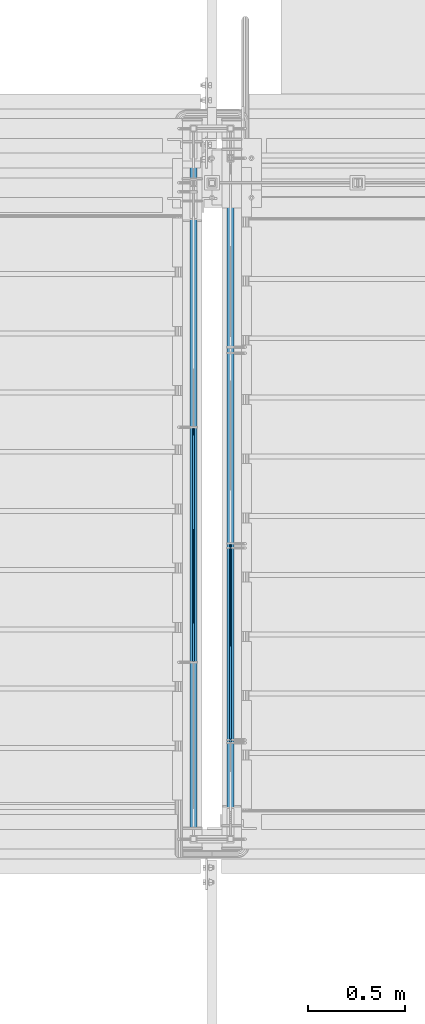
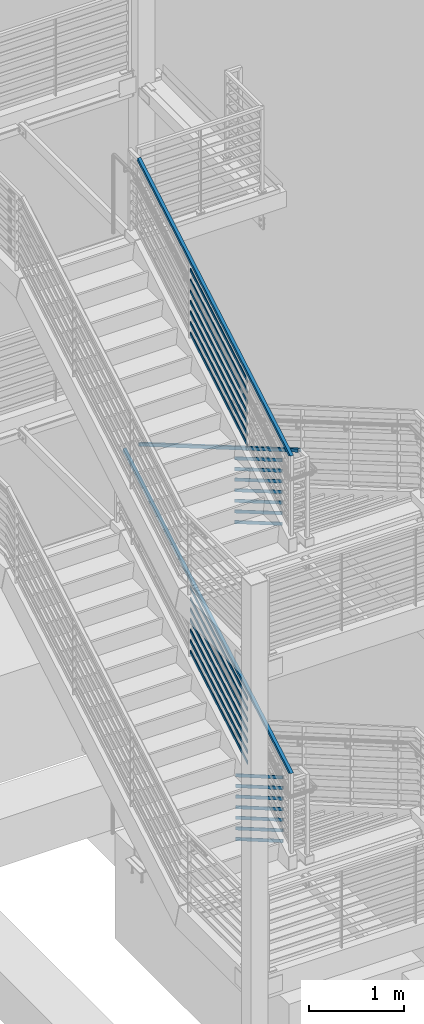
# One storey, part 755 of 1179: 31 members, 4 elements without a shape of their own.
"""IFC2X3 building model written with IfcOpenShell, lengths in millimetres."""

from ifc_helpers import new_model, si_unit, frame, origin_with_axes, place, context, subcontext, project, spatial, faceted_brep, material, type_object, element, aggregate, save


model = new_model("IFC2X3")

# Units and contexts
model_context = context("Model", 3, precision=1e-05, world=origin_with_axes())
body_context = subcontext(model_context, "Body", "Model", "MODEL_VIEW")
ifc_project = project(units=[si_unit("LENGTHUNIT", "METRE", prefix="MILLI"), si_unit("AREAUNIT", "SQUARE_METRE"), si_unit("VOLUMEUNIT", "CUBIC_METRE"), si_unit("MASSUNIT", "GRAM", prefix="KILO"), si_unit("TIMEUNIT", "SECOND"), si_unit("PLANEANGLEUNIT", "RADIAN"), si_unit("SOLIDANGLEUNIT", "STERADIAN"), si_unit("THERMODYNAMICTEMPERATUREUNIT", "DEGREE_CELSIUS"), si_unit("LUMINOUSINTENSITYUNIT", "LUMEN")], contexts=[model_context])

# Site, building, storey
site_placement = place(None, origin_with_axes())
site = spatial("IfcSite", under=ifc_project, at=site_placement, CompositionType="ELEMENT")
building_placement = place(site_placement, origin_with_axes())
building = spatial("IfcBuilding", under=site, at=building_placement, Name="Undefined", CompositionType="ELEMENT")
storey_placement = place(building_placement, origin_with_axes())
storey = spatial("IfcBuildingStorey", under=building, at=storey_placement, Name="Undefined", CompositionType="ELEMENT", Elevation=0.0)

# Assembly, members
assembly_1_placement = place(storey_placement, origin_with_axes())
assembly_1 = element("IfcElementAssembly", 1, at=assembly_1_placement, inside=storey, Name="GUARDRAIL", AssemblyPlace="NOTDEFINED", PredefinedType="RIGID_FRAME")
ifc_material_1 = material(Name="STEEL/A36")
member_type_1 = type_object("IfcMemberType", PredefinedType="NOTDEFINED")
member_1_placement = place(assembly_1_placement, frame((-1847.85000153055, 33867.7987430395, 7638.46554249568), z_axis=(0.0, -0.503871025834967, 0.863778900717086), x_axis=(0.0, -0.863778900717086, -0.503871025834967)))
member_1 = element("IfcMember", 2, at=member_1_placement, type_object=member_type_1, material=ifc_material_1, Name="PLATE", context=body_context, shape_type="Brep", body=[
    faceted_brep([(27.7385637234547, 4.76250000000005, -19.0500000000011), (5.51356370517169, 4.76250000000005, 19.0500000000338), (1396.15685487731, 4.76250000000005, 19.0500000012689), (1418.38185489559, 4.76250000000005, -19.049999998766), (5.51356370517169, -4.76250000000005, 19.0500000000338), (1396.15685487731, -4.76250000000005, 19.0500000012689), (27.7385637234547, -4.76250000000005, -19.0500000000011), (1418.38185489559, -4.76250000000005, -19.049999998766)], [[[0, 1, 2, 3]], [[1, 4, 5, 2]], [[4, 6, 7, 5]], [[6, 0, 3, 7]], [[5, 7, 3, 2]], [[6, 4, 1, 0]]]),
])
member_2_placement = place(assembly_1_placement, frame((-1847.85000153055, 33867.7987430395, 7774.64905217142), z_axis=(0.0, -0.503871025834967, 0.863778900717086), x_axis=(0.0, -0.863778900717086, -0.503871025834967)))
member_2 = element("IfcMember", 3, at=member_2_placement, type_object=member_type_1, material=ifc_material_1, Name="PLATE", context=body_context, shape_type="Brep", body=[
    faceted_brep([(27.7385637234547, 4.76250000000005, -19.0500000000011), (5.51356370517169, 4.76250000000005, 19.0500000000338), (1396.15685487731, 4.76250000000005, 19.0500000012689), (1418.38185489559, 4.76250000000005, -19.049999998766), (5.51356370517169, -4.76250000000005, 19.0500000000338), (1396.15685487731, -4.76250000000005, 19.0500000012689), (27.7385637234547, -4.76250000000005, -19.0500000000011), (1418.38185489559, -4.76250000000005, -19.049999998766)], [[[0, 1, 2, 3]], [[1, 4, 5, 2]], [[4, 6, 7, 5]], [[6, 0, 3, 7]], [[5, 7, 3, 2]], [[6, 4, 1, 0]]]),
])
member_3_placement = place(assembly_1_placement, frame((-1847.85000153055, 33867.7987430394, 7910.83256184716), z_axis=(0.0, -0.503871025834967, 0.863778900717086), x_axis=(0.0, -0.863778900717086, -0.503871025834967)))
member_3 = element("IfcMember", 4, at=member_3_placement, type_object=member_type_1, material=ifc_material_1, Name="PLATE", context=body_context, shape_type="Brep", body=[
    faceted_brep([(27.7385637234547, 4.76250000000005, -19.0500000000011), (5.51356370517169, 4.76250000000005, 19.0500000000338), (1396.15685487731, 4.76250000000005, 19.0500000012689), (1418.38185489559, 4.76250000000005, -19.049999998766), (5.51356370517169, -4.76250000000005, 19.0500000000338), (1396.15685487731, -4.76250000000005, 19.0500000012689), (27.7385637234547, -4.76250000000005, -19.0500000000011), (1418.38185489559, -4.76250000000005, -19.049999998766)], [[[0, 1, 2, 3]], [[1, 4, 5, 2]], [[4, 6, 7, 5]], [[6, 0, 3, 7]], [[5, 7, 3, 2]], [[6, 4, 1, 0]]]),
])
member_4_placement = place(assembly_1_placement, frame((-1847.85000153055, 33867.7987430394, 8047.01607152291), z_axis=(0.0, -0.503871025834967, 0.863778900717086), x_axis=(0.0, -0.863778900717086, -0.503871025834967)))
member_4 = element("IfcMember", 5, at=member_4_placement, type_object=member_type_1, material=ifc_material_1, Name="PLATE", context=body_context, shape_type="Brep", body=[
    faceted_brep([(27.7385637234547, 4.76250000000005, -19.0500000000011), (5.51356370517169, 4.76250000000005, 19.0500000000338), (1396.15685487731, 4.76250000000005, 19.0500000012689), (1418.38185489559, 4.76250000000005, -19.049999998766), (5.51356370517169, -4.76250000000005, 19.0500000000338), (1396.15685487731, -4.76250000000005, 19.0500000012689), (27.7385637234547, -4.76250000000005, -19.0500000000011), (1418.38185489559, -4.76250000000005, -19.049999998766)], [[[0, 1, 2, 3]], [[1, 4, 5, 2]], [[4, 6, 7, 5]], [[6, 0, 3, 7]], [[5, 7, 3, 2]], [[6, 4, 1, 0]]]),
])
member_5_placement = place(assembly_1_placement, frame((-1847.85000153055, 33867.7987430395, 8183.19958119865), z_axis=(0.0, -0.503871025834967, 0.863778900717086), x_axis=(0.0, -0.863778900717086, -0.503871025834967)))
member_5 = element("IfcMember", 6, at=member_5_placement, type_object=member_type_1, material=ifc_material_1, Name="PLATE", context=body_context, shape_type="Brep", body=[
    faceted_brep([(27.7385637234547, 4.76250000000005, -19.0500000000011), (5.51356370517169, 4.76250000000005, 19.0500000000338), (1396.15685487731, 4.76250000000005, 19.0500000012689), (1418.38185489559, 4.76250000000005, -19.049999998766), (5.51356370517169, -4.76250000000005, 19.0500000000338), (1396.15685487731, -4.76250000000005, 19.0500000012689), (27.7385637234547, -4.76250000000005, -19.0500000000011), (1418.38185489559, -4.76250000000005, -19.049999998766)], [[[0, 1, 2, 3]], [[1, 4, 5, 2]], [[4, 6, 7, 5]], [[6, 0, 3, 7]], [[5, 7, 3, 2]], [[6, 4, 1, 0]]]),
])
member_6_placement = place(assembly_1_placement, frame((-1847.85000153055, 33867.7987430396, 8319.38309087311), z_axis=(0.0, -0.503871025834967, 0.863778900717086), x_axis=(0.0, -0.863778900717086, -0.503871025834967)))
member_6 = element("IfcMember", 7, at=member_6_placement, type_object=member_type_1, material=ifc_material_1, Name="PLATE", context=body_context, shape_type="Brep", body=[
    faceted_brep([(27.7385637234547, 4.76250000000005, -19.0500000000011), (5.51356370517169, 4.76250000000005, 19.0500000000338), (1396.15685487731, 4.76250000000005, 19.0500000012689), (1418.38185489559, 4.76250000000005, -19.049999998766), (5.51356370517169, -4.76250000000005, 19.0500000000338), (1396.15685487731, -4.76250000000005, 19.0500000012689), (27.7385637234547, -4.76250000000005, -19.0500000000011), (1418.38185489559, -4.76250000000005, -19.049999998766)], [[[0, 1, 2, 3]], [[1, 4, 5, 2]], [[4, 6, 7, 5]], [[6, 0, 3, 7]], [[5, 7, 3, 2]], [[6, 4, 1, 0]]]),
])
member_7_placement = place(assembly_1_placement, frame((-1847.85000153055, 33867.7987430405, 8455.56660054883), z_axis=(0.0, -0.503871025834967, 0.863778900717086), x_axis=(0.0, -0.863778900717086, -0.503871025834967)))
member_7 = element("IfcMember", 8, at=member_7_placement, type_object=member_type_1, material=ifc_material_1, Name="PLATE", context=body_context, shape_type="Brep", body=[
    faceted_brep([(27.7385637234547, 4.76250000000005, -19.0500000000011), (5.51356370517169, 4.76250000000005, 19.0500000000338), (1396.15685487731, 4.76250000000005, 19.0500000012689), (1418.38185489559, 4.76250000000005, -19.049999998766), (5.51356370517169, -4.76250000000005, 19.0500000000338), (1396.15685487731, -4.76250000000005, 19.0500000012689), (27.7385637234547, -4.76250000000005, -19.0500000000011), (1418.38185489559, -4.76250000000005, -19.049999998766)], [[[0, 1, 2, 3]], [[1, 4, 5, 2]], [[4, 6, 7, 5]], [[6, 0, 3, 7]], [[5, 7, 3, 2]], [[6, 4, 1, 0]]]),
])

assembly_2_placement = place(storey_placement, origin_with_axes())
assembly_2 = element("IfcElementAssembly", 9, at=assembly_2_placement, inside=storey, Name="GUARDRAIL", AssemblyPlace="NOTDEFINED", PredefinedType="RIGID_FRAME")
member_8_placement = place(assembly_2_placement, frame((-1847.85000076555, 33867.745305077, 3556.04501363282), z_axis=(0.0, -0.501065882891537, 0.865409140812671), x_axis=(0.0, -0.86540914081267, -0.501065882891538)))
member_8 = element("IfcMember", 10, at=member_8_placement, type_object=member_type_1, material=ifc_material_1, Name="PLATE", context=body_context, shape_type="Brep", body=[
    faceted_brep([(27.5628128089447, 4.76250000000005, -19.0499999999756), (5.50317738577724, 4.76250000000005, 19.0499999999902), (1393.52680304928, 4.76249999999982, 19.0499999980784), (1415.58643847238, 4.76249999999982, -19.0500000019292), (5.50317738577724, -4.76250000000005, 19.0499999999902), (1393.52680304928, -4.76250000000027, 19.0499999980784), (27.5628128089447, -4.76250000000005, -19.0499999999756), (1415.58643847238, -4.76250000000027, -19.0500000019292)], [[[0, 1, 2, 3]], [[1, 4, 5, 2]], [[4, 6, 7, 5]], [[6, 0, 3, 7]], [[5, 7, 3, 2]], [[6, 4, 1, 0]]]),
])
member_9_placement = place(assembly_2_placement, frame((-1847.85000076555, 33867.745305077, 3692.14543259732), z_axis=(0.0, -0.501065882891537, 0.865409140812671), x_axis=(0.0, -0.86540914081267, -0.501065882891538)))
member_9 = element("IfcMember", 11, at=member_9_placement, type_object=member_type_1, material=ifc_material_1, Name="PLATE", context=body_context, shape_type="Brep", body=[
    faceted_brep([(27.5628128089447, 4.76250000000005, -19.0499999999756), (5.50317738577724, 4.76250000000005, 19.0499999999902), (1393.52680304928, 4.76249999999982, 19.0499999980784), (1415.58643847238, 4.76249999999982, -19.0500000019292), (5.50317738577724, -4.76250000000005, 19.0499999999902), (1393.52680304928, -4.76250000000027, 19.0499999980784), (27.5628128089447, -4.76250000000005, -19.0499999999756), (1415.58643847238, -4.76250000000027, -19.0500000019292)], [[[0, 1, 2, 3]], [[1, 4, 5, 2]], [[4, 6, 7, 5]], [[6, 0, 3, 7]], [[5, 7, 3, 2]], [[6, 4, 1, 0]]]),
])
member_10_placement = place(assembly_2_placement, frame((-1847.85000076555, 33867.745305077, 3828.24585156183), z_axis=(0.0, -0.501065882891537, 0.865409140812671), x_axis=(0.0, -0.86540914081267, -0.501065882891538)))
member_10 = element("IfcMember", 12, at=member_10_placement, type_object=member_type_1, material=ifc_material_1, Name="PLATE", context=body_context, shape_type="Brep", body=[
    faceted_brep([(27.5628128089447, 4.76250000000005, -19.0499999999756), (5.50317738577724, 4.76250000000005, 19.0499999999902), (1393.52680304928, 4.76249999999982, 19.0499999980784), (1415.58643847238, 4.76249999999982, -19.0500000019292), (5.50317738577724, -4.76250000000005, 19.0499999999902), (1393.52680304928, -4.76250000000027, 19.0499999980784), (27.5628128089447, -4.76250000000005, -19.0499999999756), (1415.58643847238, -4.76250000000027, -19.0500000019292)], [[[0, 1, 2, 3]], [[1, 4, 5, 2]], [[4, 6, 7, 5]], [[6, 0, 3, 7]], [[5, 7, 3, 2]], [[6, 4, 1, 0]]]),
])
member_11_placement = place(assembly_2_placement, frame((-1847.85000076555, 33867.745305077, 3964.34627052634), z_axis=(0.0, -0.501065882891537, 0.865409140812671), x_axis=(0.0, -0.86540914081267, -0.501065882891538)))
member_11 = element("IfcMember", 13, at=member_11_placement, type_object=member_type_1, material=ifc_material_1, Name="PLATE", context=body_context, shape_type="Brep", body=[
    faceted_brep([(27.5628128089447, 4.76250000000005, -19.0499999999756), (5.50317738577724, 4.76250000000005, 19.0499999999902), (1393.52680304928, 4.76249999999982, 19.0499999980784), (1415.58643847238, 4.76249999999982, -19.0500000019292), (5.50317738577724, -4.76250000000005, 19.0499999999902), (1393.52680304928, -4.76250000000027, 19.0499999980784), (27.5628128089447, -4.76250000000005, -19.0499999999756), (1415.58643847238, -4.76250000000027, -19.0500000019292)], [[[0, 1, 2, 3]], [[1, 4, 5, 2]], [[4, 6, 7, 5]], [[6, 0, 3, 7]], [[5, 7, 3, 2]], [[6, 4, 1, 0]]]),
])
member_12_placement = place(assembly_2_placement, frame((-1847.85000076555, 33867.7453050769, 4100.44668949085), z_axis=(0.0, -0.501065882891537, 0.865409140812671), x_axis=(0.0, -0.86540914081267, -0.501065882891538)))
member_12 = element("IfcMember", 14, at=member_12_placement, type_object=member_type_1, material=ifc_material_1, Name="PLATE", context=body_context, shape_type="Brep", body=[
    faceted_brep([(27.5628128089447, 4.76250000000005, -19.0499999999756), (5.50317738577724, 4.76250000000005, 19.0499999999902), (1393.52680304928, 4.76249999999982, 19.0499999980784), (1415.58643847238, 4.76249999999982, -19.0500000019292), (5.50317738577724, -4.76250000000005, 19.0499999999902), (1393.52680304928, -4.76250000000027, 19.0499999980784), (27.5628128089447, -4.76250000000005, -19.0499999999756), (1415.58643847238, -4.76250000000027, -19.0500000019292)], [[[0, 1, 2, 3]], [[1, 4, 5, 2]], [[4, 6, 7, 5]], [[6, 0, 3, 7]], [[5, 7, 3, 2]], [[6, 4, 1, 0]]]),
])
member_13_placement = place(assembly_2_placement, frame((-1847.85000076555, 33867.7453050767, 4236.54710845536), z_axis=(0.0, -0.501065882891537, 0.865409140812671), x_axis=(0.0, -0.86540914081267, -0.501065882891538)))
member_13 = element("IfcMember", 15, at=member_13_placement, type_object=member_type_1, material=ifc_material_1, Name="PLATE", context=body_context, shape_type="Brep", body=[
    faceted_brep([(27.5628128089447, 4.76250000000005, -19.0499999999756), (5.50317738577724, 4.76250000000005, 19.0499999999902), (1393.52680304928, 4.76249999999982, 19.0499999980784), (1415.58643847238, 4.76249999999982, -19.0500000019292), (5.50317738577724, -4.76250000000005, 19.0499999999902), (1393.52680304928, -4.76250000000027, 19.0499999980784), (27.5628128089447, -4.76250000000005, -19.0499999999756), (1415.58643847238, -4.76250000000027, -19.0500000019292)], [[[0, 1, 2, 3]], [[1, 4, 5, 2]], [[4, 6, 7, 5]], [[6, 0, 3, 7]], [[5, 7, 3, 2]], [[6, 4, 1, 0]]]),
])
member_14_placement = place(assembly_2_placement, frame((-1847.85000076555, 33867.7453050755, 4372.64752741987), z_axis=(0.0, -0.501065882891537, 0.865409140812671), x_axis=(0.0, -0.86540914081267, -0.501065882891538)))
member_14 = element("IfcMember", 16, at=member_14_placement, type_object=member_type_1, material=ifc_material_1, Name="PLATE", context=body_context, shape_type="Brep", body=[
    faceted_brep([(27.5628128089447, 4.76250000000005, -19.0499999999756), (5.50317738577724, 4.76250000000005, 19.0499999999902), (1393.52680304928, 4.76249999999982, 19.0499999980784), (1415.58643847238, 4.76249999999982, -19.0500000019292), (5.50317738577724, -4.76250000000005, 19.0499999999902), (1393.52680304928, -4.76250000000027, 19.0499999980784), (27.5628128089447, -4.76250000000005, -19.0499999999756), (1415.58643847238, -4.76250000000027, -19.0500000019292)], [[[0, 1, 2, 3]], [[1, 4, 5, 2]], [[4, 6, 7, 5]], [[6, 0, 3, 7]], [[5, 7, 3, 2]], [[6, 4, 1, 0]]]),
])

assembly_3_placement = place(storey_placement, origin_with_axes())
assembly_3 = element("IfcElementAssembly", 17, at=assembly_3_placement, inside=storey, Name="GUARDRAIL", AssemblyPlace="NOTDEFINED", PredefinedType="RIGID_FRAME")
member_15_placement = place(assembly_3_placement, frame((-1657.3499991948, 33249.1606265613, 5511.75810367378), z_axis=(0.0, 0.503871025834968, 0.863778900717086), x_axis=(0.0, -0.863778900717086, 0.503871025834967)))
member_15 = element("IfcMember", 18, at=member_15_placement, type_object=member_type_1, material=ifc_material_1, Name="PLATE", context=body_context, shape_type="Brep", body=[
    faceted_brep([(-16.7114354625264, 4.76250000000005, -19.0500000000065), (5.51356370517169, 4.76250000000005, 19.0500000000338), (1164.83261782332, 4.76250000000005, 19.0499999989988), (1142.607617805, 4.76250000000005, -19.0500000010361), (5.51356370517169, -4.76250000000005, 19.0500000000338), (1164.83261782332, -4.76250000000005, 19.0499999989988), (-16.7114354625264, -4.76250000000005, -19.0500000000065), (1142.607617805, -4.76250000000005, -19.0500000010361)], [[[0, 1, 2, 3]], [[1, 4, 5, 2]], [[4, 6, 7, 5]], [[6, 0, 3, 7]], [[5, 7, 3, 2]], [[6, 4, 1, 0]]]),
])
member_16_placement = place(assembly_3_placement, frame((-1657.3499991948, 33249.1605192293, 5647.94161334948), z_axis=(0.0, 0.503871025834968, 0.863778900717086), x_axis=(0.0, -0.863778900717086, 0.503871025834967)))
member_16 = element("IfcMember", 19, at=member_16_placement, type_object=member_type_1, material=ifc_material_1, Name="PLATE", context=body_context, shape_type="Brep", body=[
    faceted_brep([(-16.7114354625264, 4.76250000000005, -19.0500000000065), (5.51356370517169, 4.76250000000005, 19.0500000000338), (1164.83261782332, 4.76250000000005, 19.0499999989988), (1142.607617805, 4.76250000000005, -19.0500000010361), (5.51356370517169, -4.76250000000005, 19.0500000000338), (1164.83261782332, -4.76250000000005, 19.0499999989988), (-16.7114354625264, -4.76250000000005, -19.0500000000065), (1142.607617805, -4.76250000000005, -19.0500000010361)], [[[0, 1, 2, 3]], [[1, 4, 5, 2]], [[4, 6, 7, 5]], [[6, 0, 3, 7]], [[5, 7, 3, 2]], [[6, 4, 1, 0]]]),
])
member_17_placement = place(assembly_3_placement, frame((-1657.3499991948, 33249.1606836953, 5784.12512302509), z_axis=(0.0, 0.503871025834968, 0.863778900717086), x_axis=(0.0, -0.863778900717086, 0.503871025834967)))
member_17 = element("IfcMember", 20, at=member_17_placement, type_object=member_type_1, material=ifc_material_1, Name="PLATE", context=body_context, shape_type="Brep", body=[
    faceted_brep([(-16.7114354625264, 4.76250000000005, -19.0500000000065), (5.51356370517169, 4.76250000000005, 19.0500000000338), (1164.83261782332, 4.76250000000005, 19.0499999989988), (1142.607617805, 4.76250000000005, -19.0500000010361), (5.51356370517169, -4.76250000000005, 19.0500000000338), (1164.83261782332, -4.76250000000005, 19.0499999989988), (-16.7114354625264, -4.76250000000005, -19.0500000000065), (1142.607617805, -4.76250000000005, -19.0500000010361)], [[[0, 1, 2, 3]], [[1, 4, 5, 2]], [[4, 6, 7, 5]], [[6, 0, 3, 7]], [[5, 7, 3, 2]], [[6, 4, 1, 0]]]),
])
member_18_placement = place(assembly_3_placement, frame((-1657.3499991948, 33249.1602597418, 5920.30863269988), z_axis=(0.0, 0.503871025834968, 0.863778900717086), x_axis=(0.0, -0.863778900717086, 0.503871025834967)))
member_18 = element("IfcMember", 21, at=member_18_placement, type_object=member_type_1, material=ifc_material_1, Name="PLATE", context=body_context, shape_type="Brep", body=[
    faceted_brep([(-16.7114354625264, 4.76250000000005, -19.0500000000065), (5.51356370517169, 4.76250000000005, 19.0500000000338), (1164.83261782332, 4.76250000000005, 19.0499999989988), (1142.607617805, 4.76250000000005, -19.0500000010361), (5.51356370517169, -4.76250000000005, 19.0500000000338), (1164.83261782332, -4.76250000000005, 19.0499999989988), (-16.7114354625264, -4.76250000000005, -19.0500000000065), (1142.607617805, -4.76250000000005, -19.0500000010361)], [[[0, 1, 2, 3]], [[1, 4, 5, 2]], [[4, 6, 7, 5]], [[6, 0, 3, 7]], [[5, 7, 3, 2]], [[6, 4, 1, 0]]]),
])
member_19_placement = place(assembly_3_placement, frame((-1657.3499991948, 33249.1605812497, 6056.49214237508), z_axis=(0.0, 0.503871025834968, 0.863778900717086), x_axis=(0.0, -0.863778900717086, 0.503871025834967)))
member_19 = element("IfcMember", 22, at=member_19_placement, type_object=member_type_1, material=ifc_material_1, Name="PLATE", context=body_context, shape_type="Brep", body=[
    faceted_brep([(-16.7114354625264, 4.76250000000005, -19.0500000000065), (5.51356370517169, 4.76250000000005, 19.0500000000338), (1164.83261782332, 4.76250000000005, 19.0499999989988), (1142.607617805, 4.76250000000005, -19.0500000010361), (5.51356370517169, -4.76250000000005, 19.0500000000338), (1164.83261782332, -4.76250000000005, 19.0499999989988), (-16.7114354625264, -4.76250000000005, -19.0500000000065), (1142.607617805, -4.76250000000005, -19.0500000010361)], [[[0, 1, 2, 3]], [[1, 4, 5, 2]], [[4, 6, 7, 5]], [[6, 0, 3, 7]], [[5, 7, 3, 2]], [[6, 4, 1, 0]]]),
])
member_20_placement = place(assembly_3_placement, frame((-1657.3499991948, 33249.1605813937, 6192.67565205084), z_axis=(0.0, 0.503871025834968, 0.863778900717086), x_axis=(0.0, -0.863778900717086, 0.503871025834967)))
member_20 = element("IfcMember", 23, at=member_20_placement, type_object=member_type_1, material=ifc_material_1, Name="PLATE", context=body_context, shape_type="Brep", body=[
    faceted_brep([(-16.7114354625264, 4.76250000000005, -19.0500000000065), (5.51356370517169, 4.76250000000005, 19.0500000000338), (1164.83261782332, 4.76250000000005, 19.0499999989988), (1142.607617805, 4.76250000000005, -19.0500000010361), (5.51356370517169, -4.76250000000005, 19.0500000000338), (1164.83261782332, -4.76250000000005, 19.0499999989988), (-16.7114354625264, -4.76250000000005, -19.0500000000065), (1142.607617805, -4.76250000000005, -19.0500000010361)], [[[0, 1, 2, 3]], [[1, 4, 5, 2]], [[4, 6, 7, 5]], [[6, 0, 3, 7]], [[5, 7, 3, 2]], [[6, 4, 1, 0]]]),
])
member_21_placement = place(assembly_3_placement, frame((-1657.3499991948, 33249.1605815173, 6328.85916172661), z_axis=(0.0, 0.503871025834968, 0.863778900717086), x_axis=(0.0, -0.863778900717086, 0.503871025834967)))
member_21 = element("IfcMember", 24, at=member_21_placement, type_object=member_type_1, material=ifc_material_1, Name="PLATE", context=body_context, shape_type="Brep", body=[
    faceted_brep([(-16.7114354625264, 4.76250000000005, -19.0500000000065), (5.51356370517169, 4.76250000000005, 19.0500000000338), (1164.83261782332, 4.76250000000005, 19.0499999989988), (1142.607617805, 4.76250000000005, -19.0500000010361), (5.51356370517169, -4.76250000000005, 19.0500000000338), (1164.83261782332, -4.76250000000005, 19.0499999989988), (-16.7114354625264, -4.76250000000005, -19.0500000000065), (1142.607617805, -4.76250000000005, -19.0500000010361)], [[[0, 1, 2, 3]], [[1, 4, 5, 2]], [[4, 6, 7, 5]], [[6, 0, 3, 7]], [[5, 7, 3, 2]], [[6, 4, 1, 0]]]),
])

assembly_4_placement = place(storey_placement, origin_with_axes())
assembly_4 = element("IfcElementAssembly", 25, at=assembly_4_placement, inside=storey, Name="GUARDRAIL", AssemblyPlace="NOTDEFINED", PredefinedType="RIGID_FRAME")
member_22_placement = place(assembly_4_placement, frame((-1657.3499991948, 33226.3545031604, 1457.93853205245), z_axis=(0.0, 0.501075923252298, 0.865403327435744), x_axis=(0.0, -0.865403327435743, 0.501075923252299)))
member_22 = element("IfcMember", 26, at=member_22_placement, type_object=member_type_1, material=ifc_material_1, Name="PLATE", context=body_context, shape_type="Brep", body=[
    faceted_brep([(-16.5570104603576, 4.76250000000005, -19.0500000000102), (5.50317738577724, 4.76250000000005, 19.0499999999902), (1153.84060725657, 4.76250000000005, 19.0499999998246), (1131.78038161306, 4.76250000000005, -19.0500000001994), (5.50317738577724, -4.76250000000005, 19.0499999999902), (1153.84060725657, -4.76250000000005, 19.0499999998246), (-16.5570104603576, -4.76250000000005, -19.0500000000102), (1131.78038161306, -4.76250000000005, -19.0500000001994)], [[[0, 1, 2, 3]], [[1, 4, 5, 2]], [[4, 6, 7, 5]], [[6, 0, 3, 7]], [[5, 7, 3, 2]], [[6, 4, 1, 0]]]),
])
member_23_placement = place(assembly_4_placement, frame((-1657.3499991948, 33226.3545032929, 1594.03924668255), z_axis=(0.0, 0.501075923252298, 0.865403327435744), x_axis=(0.0, -0.865403327435743, 0.501075923252299)))
member_23 = element("IfcMember", 27, at=member_23_placement, type_object=member_type_1, material=ifc_material_1, Name="PLATE", context=body_context, shape_type="Brep", body=[
    faceted_brep([(-16.5570104603576, 4.76250000000005, -19.0500000000102), (5.50317738577724, 4.76250000000005, 19.0499999999902), (1153.84060725657, 4.76250000000005, 19.0499999998246), (1131.78038161306, 4.76250000000005, -19.0500000001994), (5.50317738577724, -4.76250000000005, 19.0499999999902), (1153.84060725657, -4.76250000000005, 19.0499999998246), (-16.5570104603576, -4.76250000000005, -19.0500000000102), (1131.78038161306, -4.76250000000005, -19.0500000001994)], [[[0, 1, 2, 3]], [[1, 4, 5, 2]], [[4, 6, 7, 5]], [[6, 0, 3, 7]], [[5, 7, 3, 2]], [[6, 4, 1, 0]]]),
])
member_24_placement = place(assembly_4_placement, frame((-1657.3499991948, 33226.3545034249, 1730.13996131292), z_axis=(0.0, 0.501075923252298, 0.865403327435744), x_axis=(0.0, -0.865403327435743, 0.501075923252299)))
member_24 = element("IfcMember", 28, at=member_24_placement, type_object=member_type_1, material=ifc_material_1, Name="PLATE", context=body_context, shape_type="Brep", body=[
    faceted_brep([(-16.5570104603576, 4.76250000000005, -19.0500000000102), (5.50317738577724, 4.76250000000005, 19.0499999999902), (1153.84060725657, 4.76250000000005, 19.0499999998246), (1131.78038161306, 4.76250000000005, -19.0500000001994), (5.50317738577724, -4.76250000000005, 19.0499999999902), (1153.84060725657, -4.76250000000005, 19.0499999998246), (-16.5570104603576, -4.76250000000005, -19.0500000000102), (1131.78038161306, -4.76250000000005, -19.0500000001994)], [[[0, 1, 2, 3]], [[1, 4, 5, 2]], [[4, 6, 7, 5]], [[6, 0, 3, 7]], [[5, 7, 3, 2]], [[6, 4, 1, 0]]]),
])
member_25_placement = place(assembly_4_placement, frame((-1657.3499991948, 33226.3545035581, 1866.24067594273), z_axis=(0.0, 0.501075923252298, 0.865403327435744), x_axis=(0.0, -0.865403327435743, 0.501075923252299)))
member_25 = element("IfcMember", 29, at=member_25_placement, type_object=member_type_1, material=ifc_material_1, Name="PLATE", context=body_context, shape_type="Brep", body=[
    faceted_brep([(-16.5570104603576, 4.76250000000005, -19.0500000000102), (5.50317738577724, 4.76250000000005, 19.0499999999902), (1153.84060725657, 4.76250000000005, 19.0499999998246), (1131.78038161306, 4.76250000000005, -19.0500000001994), (5.50317738577724, -4.76250000000005, 19.0499999999902), (1153.84060725657, -4.76250000000005, 19.0499999998246), (-16.5570104603576, -4.76250000000005, -19.0500000000102), (1131.78038161306, -4.76250000000005, -19.0500000001994)], [[[0, 1, 2, 3]], [[1, 4, 5, 2]], [[4, 6, 7, 5]], [[6, 0, 3, 7]], [[5, 7, 3, 2]], [[6, 4, 1, 0]]]),
])
member_26_placement = place(assembly_4_placement, frame((-1657.3499991948, 33226.3545036939, 2002.34139057225), z_axis=(0.0, 0.501075923252298, 0.865403327435744), x_axis=(0.0, -0.865403327435743, 0.501075923252299)))
member_26 = element("IfcMember", 30, at=member_26_placement, type_object=member_type_1, material=ifc_material_1, Name="PLATE", context=body_context, shape_type="Brep", body=[
    faceted_brep([(-16.5570104603576, 4.76250000000005, -19.0500000000102), (5.50317738577724, 4.76250000000005, 19.0499999999902), (1153.84060725657, 4.76250000000005, 19.0499999998246), (1131.78038161306, 4.76250000000005, -19.0500000001994), (5.50317738577724, -4.76250000000005, 19.0499999999902), (1153.84060725657, -4.76250000000005, 19.0499999998246), (-16.5570104603576, -4.76250000000005, -19.0500000000102), (1131.78038161306, -4.76250000000005, -19.0500000001994)], [[[0, 1, 2, 3]], [[1, 4, 5, 2]], [[4, 6, 7, 5]], [[6, 0, 3, 7]], [[5, 7, 3, 2]], [[6, 4, 1, 0]]]),
])
member_27_placement = place(assembly_4_placement, frame((-1657.3499991948, 33226.3545038456, 2138.44210520233), z_axis=(0.0, 0.501075923252298, 0.865403327435744), x_axis=(0.0, -0.865403327435743, 0.501075923252299)))
member_27 = element("IfcMember", 31, at=member_27_placement, type_object=member_type_1, material=ifc_material_1, Name="PLATE", context=body_context, shape_type="Brep", body=[
    faceted_brep([(-16.5570104603576, 4.76250000000005, -19.0500000000102), (5.50317738577724, 4.76250000000005, 19.0499999999902), (1153.84060725657, 4.76250000000005, 19.0499999998246), (1131.78038161306, 4.76250000000005, -19.0500000001994), (5.50317738577724, -4.76250000000005, 19.0499999999902), (1153.84060725657, -4.76250000000005, 19.0499999998246), (-16.5570104603576, -4.76250000000005, -19.0500000000102), (1131.78038161306, -4.76250000000005, -19.0500000001994)], [[[0, 1, 2, 3]], [[1, 4, 5, 2]], [[4, 6, 7, 5]], [[6, 0, 3, 7]], [[5, 7, 3, 2]], [[6, 4, 1, 0]]]),
])
member_28_placement = place(assembly_4_placement, frame((-1657.3499991948, 33226.3545032379, 2274.542820335), z_axis=(0.0, 0.501075923252298, 0.865403327435744), x_axis=(0.0, -0.865403327435743, 0.501075923252299)))
member_28 = element("IfcMember", 32, at=member_28_placement, type_object=member_type_1, material=ifc_material_1, Name="PLATE", context=body_context, shape_type="Brep", body=[
    faceted_brep([(-16.5570104603576, 4.76250000000005, -19.0500000000102), (5.50317738577724, 4.76250000000005, 19.0499999999902), (1153.84060725657, 4.76250000000005, 19.0499999998246), (1131.78038161306, 4.76250000000005, -19.0500000001994), (5.50317738577724, -4.76250000000005, 19.0499999999902), (1153.84060725657, -4.76250000000005, 19.0499999998246), (-16.5570104603576, -4.76250000000005, -19.0500000000102), (1131.78038161306, -4.76250000000005, -19.0500000001994)], [[[0, 1, 2, 3]], [[1, 4, 5, 2]], [[4, 6, 7, 5]], [[6, 0, 3, 7]], [[5, 7, 3, 2]], [[6, 4, 1, 0]]]),
])
aggregate(assembly_4, [member_22, member_23, member_24, member_25, member_26, member_27, member_28])

# Member
ifc_material_2 = material()
member_type_2 = type_object("IfcMemberType", Name="HSS1-1/2X1-1/2X1/4", PredefinedType="NOTDEFINED")
member_29_placement = place(assembly_1_placement, frame((-1847.85000076555, 34937.6929459655, 9213.84814639863), z_axis=(0.0, -0.504198926827172, 0.863587541703983), x_axis=(0.0, -0.863587541703982, -0.504198926827173)))
member_29 = element("IfcMember", 33, at=member_29_placement, type_object=member_type_2, material=ifc_material_2, Name="GUARDRAIL", ObjectType="HSS1-1/2X1-1/2X1/4", context=body_context, shape_type="Brep", body=[
    faceted_brep([(3.42880381045688, 12.6999993300001, -12.6999993300069), (3.42880381045688, -12.6999993300001, -12.6999993300069), (3698.63439152823, -12.6999993300001, -12.6999993315239), (3698.63439152823, 12.6999993300001, -12.6999993315239), (-3.42880137678003, -12.6999993300001, 12.6999993300105), (3713.21698563153, -12.6999993300001, 12.6999993284826), (-3.42880137678003, 12.6999993300001, 12.6999993300105), (3713.21698563153, 12.6999993300001, 12.6999993284826), (5.14320517206215, 19.0499992350001, -19.0499992350142), (-5.14320273837802, 19.0499992350001, 19.0499992350142), (3716.86263429514, 19.0499992350001, 19.0499992334862), (3694.98874286462, 19.0499992350001, -19.0499992365276), (-5.14320273837802, -19.0499992350001, 19.0499992350142), (3716.86263429514, -19.0499992350001, 19.0499992334862), (5.14320517206215, -19.0499992350001, -19.0499992350142), (3694.98874286462, -19.0499992350001, -19.0499992365276)], [[[0, 1, 2, 3]], [[1, 4, 5, 2]], [[4, 6, 7, 5]], [[6, 0, 3, 7]], [[8, 9, 10, 11]], [[9, 12, 13, 10]], [[12, 14, 15, 13]], [[14, 8, 11, 15]], [[13, 15, 11, 10], [5, 7, 3, 2]], [[14, 12, 9, 8], [6, 4, 1, 0]]]),
])

aggregate(assembly_1, [member_1, member_2, member_3, member_4, member_5, member_6, member_7, member_29])

member_30_placement = place(assembly_2_placement, frame((-1847.85000076555, 35242.4961132519, 5302.2499998321), z_axis=(0.0, -0.501395132843281, 0.865218423729562), x_axis=(0.0, -0.865218423729562, -0.501395132843281)))
member_30 = element("IfcMember", 34, at=member_30_placement, type_object=member_type_2, material=ifc_material_2, Name="GUARDRAIL", ObjectType="HSS1-1/2X1-1/2X1/4", context=body_context, shape_type="Brep", body=[
    faceted_brep([(3.40961393439648, 12.6999993300001, -12.6999993300124), (3.40961393439648, -12.6999993300001, -12.6999993300124), (4043.90814599031, -12.6999993300001, -12.6999993297341), (4043.90814599031, 12.6999993300001, -12.6999993297341), (-3.40961154065008, -12.6999993300001, 12.6999993300014), (4058.54556310125, -12.6999993300001, 12.6999993302816), (-3.40961154065008, 12.6999993300001, 12.6999993300014), (4058.54556310125, 12.6999993300001, 12.6999993302816), (5.11442036760127, 19.0499992350001, -19.049999235016), (-5.11441797385487, 19.0499992350001, 19.0499992350015), (4062.2049175173, 19.0499992350001, 19.0499992352834), (4040.24879157426, 19.0499992350001, -19.0499992347359), (-5.11441797385487, -19.0499992350001, 19.0499992350015), (4062.2049175173, -19.0499992350001, 19.0499992352834), (5.11442036760127, -19.0499992350001, -19.049999235016), (4040.24879157426, -19.0499992350001, -19.0499992347359)], [[[0, 1, 2, 3]], [[1, 4, 5, 2]], [[4, 6, 7, 5]], [[6, 0, 3, 7]], [[8, 9, 10, 11]], [[9, 12, 13, 10]], [[12, 14, 15, 13]], [[14, 8, 11, 15]], [[13, 15, 11, 10], [5, 7, 3, 2]], [[14, 12, 9, 8], [6, 4, 1, 0]]]),
])

aggregate(assembly_2, [member_8, member_9, member_10, member_11, member_12, member_13, member_14, member_30])

member_31_placement = place(assembly_3_placement, frame((-1657.34999921452, 35242.500040867, 5302.24999924027), z_axis=(0.0, 0.503874729975411, 0.863776739957848), x_axis=(0.0, -0.863776739957847, 0.503874729975411)))
member_31 = element("IfcMember", 35, at=member_31_placement, type_object=member_type_2, material=ifc_material_2, Name="GUARDRAIL", ObjectType="HSS1-1/2X1-1/2X1/4", context=body_context, shape_type="Brep", body=[
    faceted_brep([(-3.43346316217139, 12.6999993300001, -12.6999993300124), (-3.43346316217139, -12.6999993300001, -12.6999993300124), (3878.09141430044, -12.6999993300001, -12.6999993276731), (3878.09141430044, 12.6999993300001, -12.6999993276731), (3.43346312003996, -12.6999993300001, 12.6999993300087), (3884.94921947856, -12.6999993300001, 12.6999993323516), (3.43346312003996, 12.6999993300001, 12.6999993300087), (3884.94921947856, 12.6999993300001, 12.6999993323516), (-5.15015093865441, 19.0499992350015, -19.049999234986), (5.15015095151102, 19.0499992350015, 19.0499992349869), (3886.66367083789, 19.0499992350001, 19.0499992373552), (3876.37696294112, 19.0499992350001, -19.0499992326768), (5.15015095151102, -19.0499992350015, 19.0499992349869), (3886.66367083789, -19.0499992350001, 19.0499992373552), (-5.15015093865441, -19.0499992350015, -19.049999234986), (3876.37696294112, -19.0499992350001, -19.0499992326768)], [[[0, 1, 2, 3]], [[1, 4, 5, 2]], [[4, 6, 7, 5]], [[6, 0, 3, 7]], [[8, 9, 10, 11]], [[9, 12, 13, 10]], [[12, 14, 15, 13]], [[14, 8, 11, 15]], [[13, 15, 11, 10], [5, 7, 3, 2]], [[14, 12, 9, 8], [6, 4, 1, 0]]]),
])

aggregate(assembly_3, [member_15, member_16, member_17, member_18, member_19, member_20, member_21, member_31])

save(model, "model.ifc")
